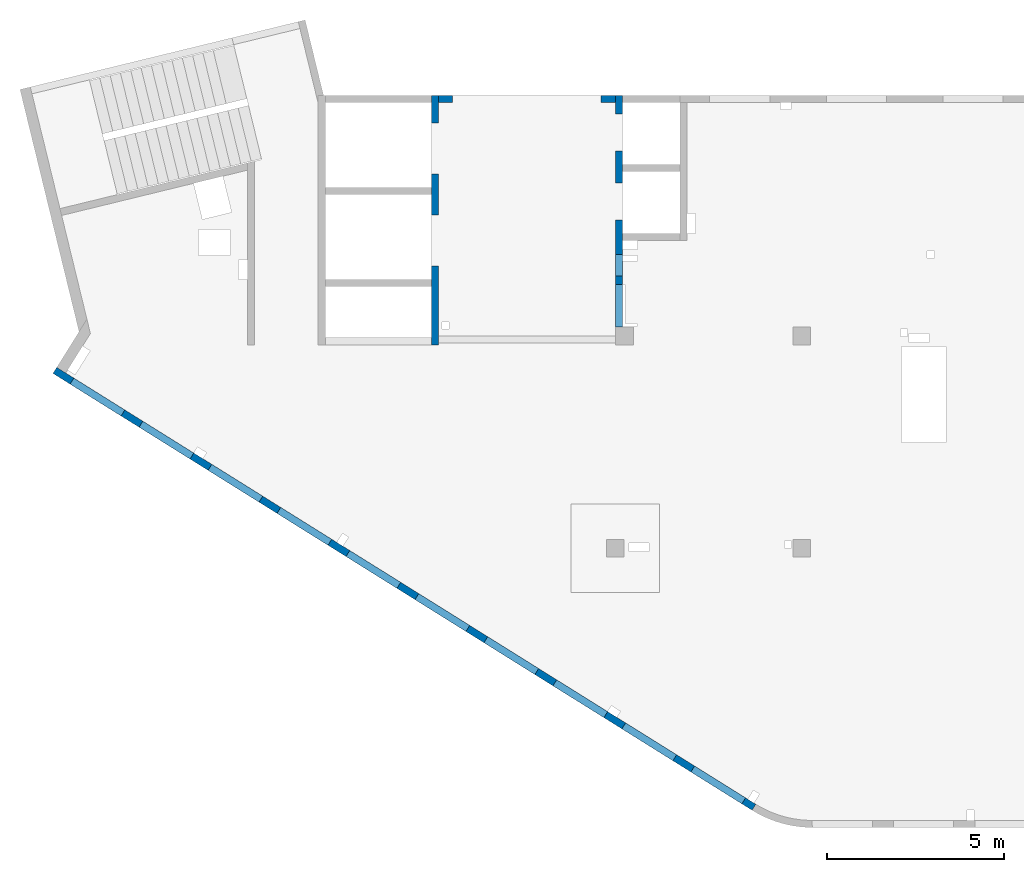
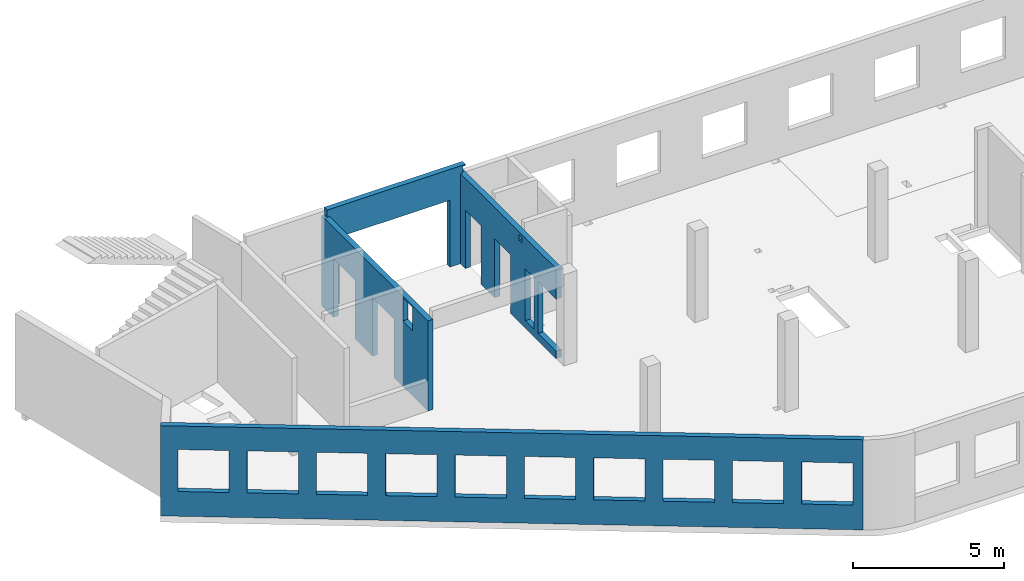
# One storey, part 4 of 6: 4 walls, 19 openings.
"""IFC4 building model written with IfcOpenShell, lengths in millimetres."""

from ifc_helpers import new_model, entity, si_unit, converted_unit, derived_unit, direction, frame, origin, place, context, subcontext, project, spatial, indexed_curve, outline, extrude, polygons, material, type_object, element, save


model = new_model("IFC4")

# Units and contexts
model_context = context("Model", 3, precision=0.01, world=origin(), true_north=direction((6.12303176911189e-17, 1.0)))
plan_context = context("Plan", 3, precision=0.01, world=origin(), true_north=direction((6.12303176911189e-17, 1.0)))
body_context = subcontext(model_context, "Body", "Model", "MODEL_VIEW")
ifc_project = project(units=[si_unit("LENGTHUNIT", "METRE", prefix="MILLI"), si_unit("AREAUNIT", "SQUARE_METRE"), si_unit("VOLUMEUNIT", "CUBIC_METRE"), converted_unit("PLANEANGLEUNIT", "DEGREE", entity("IfcRatioMeasure", 0.0174532925199433), si_unit("PLANEANGLEUNIT", "RADIAN"), dimensions=[0, 0, 0, 0, 0, 0, 0]), si_unit("MASSUNIT", "GRAM", prefix="KILO"), derived_unit("MASSDENSITYUNIT", [(si_unit("MASSUNIT", "GRAM", prefix="KILO"), 1), (si_unit("LENGTHUNIT", "METRE"), -3)]), derived_unit("MOMENTOFINERTIAUNIT", [(si_unit("LENGTHUNIT", "METRE"), 4)]), si_unit("TIMEUNIT", "SECOND"), si_unit("FREQUENCYUNIT", "HERTZ"), si_unit("THERMODYNAMICTEMPERATUREUNIT", "DEGREE_CELSIUS"), derived_unit("THERMALTRANSMITTANCEUNIT", [(si_unit("MASSUNIT", "GRAM", prefix="KILO"), 1), (si_unit("THERMODYNAMICTEMPERATUREUNIT", "KELVIN"), -1), (si_unit("TIMEUNIT", "SECOND"), -3)]), derived_unit("VOLUMETRICFLOWRATEUNIT", [(si_unit("LENGTHUNIT", "METRE"), 3), (si_unit("TIMEUNIT", "SECOND"), -1)]), derived_unit("MASSFLOWRATEUNIT", [(si_unit("MASSUNIT", "GRAM", prefix="KILO"), 1), (si_unit("TIMEUNIT", "SECOND"), -1)]), derived_unit("ROTATIONALFREQUENCYUNIT", [(si_unit("TIMEUNIT", "SECOND"), -1)]), si_unit("ELECTRICCURRENTUNIT", "AMPERE"), si_unit("ELECTRICVOLTAGEUNIT", "VOLT"), si_unit("POWERUNIT", "WATT"), si_unit("FORCEUNIT", "NEWTON", prefix="KILO"), si_unit("ILLUMINANCEUNIT", "LUX"), si_unit("LUMINOUSFLUXUNIT", "LUMEN"), si_unit("LUMINOUSINTENSITYUNIT", "CANDELA"), derived_unit("USERDEFINED", [(si_unit("MASSUNIT", "GRAM", prefix="KILO"), -1), (si_unit("LENGTHUNIT", "METRE"), -2), (si_unit("TIMEUNIT", "SECOND"), 3), (si_unit("LUMINOUSFLUXUNIT", "LUMEN"), 1)]), derived_unit("LINEARVELOCITYUNIT", [(si_unit("LENGTHUNIT", "METRE"), 1), (si_unit("TIMEUNIT", "SECOND"), -1)]), si_unit("PRESSUREUNIT", "PASCAL"), derived_unit("USERDEFINED", [(si_unit("LENGTHUNIT", "METRE"), -2), (si_unit("MASSUNIT", "GRAM", prefix="KILO"), 1), (si_unit("TIMEUNIT", "SECOND"), -2)]), derived_unit("LINEARFORCEUNIT", [(si_unit("MASSUNIT", "GRAM", prefix="KILO"), 1), (si_unit("LENGTHUNIT", "METRE"), 1), (si_unit("TIMEUNIT", "SECOND"), -2), (si_unit("LENGTHUNIT", "METRE"), -1)]), derived_unit("PLANARFORCEUNIT", [(si_unit("MASSUNIT", "GRAM", prefix="KILO"), 1), (si_unit("LENGTHUNIT", "METRE"), 1), (si_unit("TIMEUNIT", "SECOND"), -2), (si_unit("LENGTHUNIT", "METRE"), -2)])], contexts=[model_context, plan_context])

# Site, building, storey
site_placement = place(None, origin())
site = spatial("IfcSite", under=ifc_project, at=site_placement, CompositionType="ELEMENT")
building_placement = place(site_placement, origin())
building = spatial("IfcBuilding", under=site, at=building_placement, CompositionType="ELEMENT")
storey_placement = place(building_placement, frame((0.0, 0.0, 8100.0)))
storey = spatial("IfcBuildingStorey", under=building, at=storey_placement, CompositionType="ELEMENT", Elevation=8100.0)

# Wall, openings
ifc_material = material()
wall_type = type_object("IfcWallType", PredefinedType="STANDARD")
wall_1_placement = place(storey_placement, frame((19822.3508929728, 371.159406986362, -150.0), z_axis=(0.0, 0.0, 1.0), x_axis=(-0.848052743777574, 0.529911826412025, 0.0)))
wall_1 = element("IfcWall", 1, at=wall_1_placement, inside=storey, type_object=wall_type, material=ifc_material, PredefinedType="NOTDEFINED", context=body_context, shape_type="Tessellation", body=[
    polygons([(341.63903172165, -99.9999999999988, 2700.0), (2041.63903172165, -99.9999999999981, 2700.0), (2041.63903172165, -99.9999999999981, 1000.00000000001), (341.63903172165, -99.9999999999988, 1000.00000000001), (2641.63903172165, -99.9999999999995, 2700.0), (4341.63903172165, -99.9999999999992, 2700.0), (4341.63903172165, -99.9999999999992, 1000.00000000001), (2641.63903172165, -99.9999999999995, 1000.00000000001), (4941.63903172166, -100.0, 2700.0), (6641.63903172166, -99.9999999999984, 2700.0), (6641.63903172166, -99.9999999999984, 1000.00000000001), (4941.63903172166, -100.0, 1000.00000000001), (7241.63903172167, -99.9999999999984, 2700.0), (8941.63903172167, -100.0, 2700.0), (8941.63903172167, -100.0, 1000.00000000001), (7241.63903172167, -99.9999999999984, 1000.00000000001), (9541.63903172167, -100.0, 2700.0), (11241.6390317217, -99.9999999999989, 2700.0), (11241.6390317217, -99.9999999999989, 1000.00000000001), (9541.63903172167, -100.0, 1000.00000000001), (11841.6390317217, -100.0, 2700.0), (13541.6390317217, -100.0, 2700.0), (13541.6390317217, -100.0, 1000.00000000001), (11841.6390317217, -100.0, 1000.00000000001), (14141.6390317217, -100.0, 2700.0), (15841.6390317217, -100.0, 2700.0), (15841.6390317217, -100.0, 1000.00000000001), (14141.6390317217, -100.0, 1000.00000000001), (16441.6390317217, -99.9999999999989, 2700.0), (18141.6390317217, -99.9999999999989, 2700.0), (18141.6390317217, -99.9999999999989, 1000.00000000001), (16441.6390317217, -99.9999999999989, 1000.00000000001), (18741.6390317217, -100.0, 2700.0), (20441.6390317217, -99.9999999999989, 2700.0), (20441.6390317217, -99.9999999999989, 1000.00000000001), (18741.6390317217, -100.0, 1000.00000000001), (21041.6390317217, -99.9999999999989, 2700.0), (22741.6390317217, -100.000000000001, 2700.0), (22741.6390317217, -100.000000000001, 1000.00000000001), (21041.6390317217, -99.9999999999989, 1000.00000000001), (-1.48894230278529e-12, -99.9999999999978, 0.0), (66.6340806380096, -99.9999999999985, 0.0), (266.636711734731, -99.9999999999993, 0.0), (4641.63671190304, -99.9999999999984, 0.0), (4941.63495785519, -100.0, 0.0), (13771.6340811649, -99.9999999999989, 0.0), (13971.6367122616, -100.000000000001, 0.0), (18441.6367124338, -100.0, 0.0), (18741.6390317217, -100.0, 0.0), (23011.6394501553, -99.9999999999989, 0.0), (23311.6394501553, -99.9999999999989, 0.0), (23311.6394501553, -99.9999999999989, 3650.0), (23011.6394501553, -99.9999999999989, 3650.0), (-1.48894230278529e-12, -99.9999999999978, 3650.0), (-2.26725305196851e-12, 100.000000000001, 0.0), (-2.26725305196851e-12, 100.000000000001, 3650.0), (23311.6394501553, 100.000000000001, 3650.0), (23311.6394501553, 99.9999999999989, 0.0), (2041.63903172165, 100.000000000323, 2700.0), (341.63903172165, 100.000000000321, 2700.0), (341.63903172165, 100.000000000321, 1000.00000000001), (2041.63903172165, 100.000000000323, 1000.00000000001), (4341.63903172165, 100.000000000322, 2700.0), (2641.63903172165, 100.00000000032, 2700.0), (2641.63903172165, 100.00000000032, 1000.00000000001), (4341.63903172165, 100.000000000322, 1000.00000000001), (6641.63903172166, 100.000000000322, 2700.0), (4941.63903172166, 100.000000000321, 2700.0), (4941.63903172166, 100.000000000321, 1000.00000000001), (6641.63903172166, 100.000000000322, 1000.00000000001), (8941.63903172166, 100.000000000321, 2700.0), (7241.63903172167, 100.000000000322, 2700.0), (7241.63903172167, 100.000000000322, 1000.00000000001), (8941.63903172166, 100.000000000321, 1000.00000000001), (11241.6390317217, 100.000000000323, 2700.0), (9541.63903172167, 100.000000000321, 2700.0), (9541.63903172167, 100.000000000321, 1000.00000000001), (11241.6390317217, 100.000000000323, 1000.00000000001), (13541.6390317217, 100.000000000319, 2700.0), (11841.6390317217, 100.000000000323, 2700.0), (11841.6390317217, 100.000000000323, 1000.00000000001), (13541.6390317217, 100.000000000319, 1000.00000000001), (15841.6390317217, 100.000000000322, 2700.0), (14141.6390317217, 100.000000000322, 2700.0), (14141.6390317217, 100.000000000322, 1000.00000000001), (15841.6390317217, 100.000000000322, 1000.00000000001), (18141.6390317217, 100.000000000322, 2700.0), (16441.6390317217, 100.000000000322, 2700.0), (16441.6390317217, 100.000000000322, 1000.00000000001), (18141.6390317217, 100.000000000322, 1000.00000000001), (20441.6390317217, 100.000000000322, 2700.0), (18741.6390317217, 100.000000000319, 2700.0), (18741.6390317217, 100.000000000319, 1000.00000000001), (20441.6390317217, 100.000000000322, 1000.00000000001), (22741.6390317217, 100.000000000319, 2700.0), (21041.6390317217, 100.000000000321, 2700.0), (21041.6390317217, 100.000000000323, 1000.00000000001), (22741.6390317217, 100.000000000319, 1000.00000000001)], [[[41, 42, 43, 44, 45, 46, 47, 48, 49, 50, 51, 52, 53, 54], [1, 2, 3, 4], [5, 6, 7, 8], [9, 10, 11, 12], [13, 14, 15, 16], [17, 18, 19, 20], [21, 22, 23, 24], [25, 26, 27, 28], [29, 30, 31, 32], [33, 34, 35, 36], [37, 38, 39, 40]], [[55, 56, 57, 58], [59, 60, 61, 62], [63, 64, 65, 66], [67, 68, 69, 70], [71, 72, 73, 74], [75, 76, 77, 78], [79, 80, 81, 82], [83, 84, 85, 86], [87, 88, 89, 90], [91, 92, 93, 94], [95, 96, 97, 98]], [[51, 50, 49, 48, 47, 46, 45, 44, 43, 42, 41, 55, 58]], [[54, 53, 52, 57, 56]], [[41, 54, 56, 55]], [[52, 51, 58, 57]], [[60, 59, 2, 1]], [[60, 1, 4, 61]], [[61, 4, 3, 62]], [[2, 59, 62, 3]], [[64, 63, 6, 5]], [[64, 5, 8, 65]], [[65, 8, 7, 66]], [[6, 63, 66, 7]], [[68, 67, 10, 9]], [[68, 9, 12, 69]], [[69, 12, 11, 70]], [[10, 67, 70, 11]], [[72, 71, 14, 13]], [[72, 13, 16, 73]], [[73, 16, 15, 74]], [[14, 71, 74, 15]], [[76, 75, 18, 17]], [[76, 17, 20, 77]], [[77, 20, 19, 78]], [[18, 75, 78, 19]], [[80, 79, 22, 21]], [[80, 21, 24, 81]], [[81, 24, 23, 82]], [[22, 79, 82, 23]], [[84, 83, 26, 25]], [[84, 25, 28, 85]], [[85, 28, 27, 86]], [[26, 83, 86, 27]], [[88, 87, 30, 29]], [[88, 29, 32, 89]], [[89, 32, 31, 90]], [[30, 87, 90, 31]], [[92, 91, 34, 33]], [[92, 33, 36, 93]], [[93, 36, 35, 94]], [[34, 91, 94, 35]], [[96, 95, 38, 37]], [[96, 37, 40, 97]], [[97, 40, 39, 98]], [[38, 95, 98, 39]]], closed=True),
])
opening_1_placement = place(wall_1_placement, frame((16613.7173036613, 10818.8609189489, 150.0), z_axis=(0.0, 0.0, 1.0), x_axis=(-0.848052743777574, -0.529911826412026, 0.0)))
element("IfcOpeningElement", 2, at=opening_1_placement, cuts=wall_1, PredefinedType="OPENING", context=body_context, shape_type="SweptSolid", body=[
    extrude(outline(indexed_curve([(-849.999999999993, -850.0), (849.999999999994, -850.0), (849.999999999994, 850.0), (-849.999999999993, 850.0), (-849.999999999993, -850.0)], self_intersect=False)), frame((1310.07752897417, 12056.6031038165, 1700.0), z_axis=(-0.529911826412026, -0.848052743777574, 0.0), x_axis=(0.0, 0.0, -1.0)), (0.0, 0.0, 1.0), 200.000000000964),
])
opening_2_placement = place(wall_1_placement, frame((16613.7173036613, 10818.8609189489, 150.0), z_axis=(0.0, 0.0, 1.0), x_axis=(-0.848052743777574, -0.529911826412026, 0.0)))
element("IfcOpeningElement", 3, at=opening_2_placement, cuts=wall_1, PredefinedType="OPENING", context=body_context, shape_type="SweptSolid", body=[
    extrude(outline(indexed_curve([(-849.999999999993, -850.0), (849.999999999994, -850.0), (849.999999999994, 850.0), (-849.999999999993, 850.0), (-849.999999999993, -850.0)], self_intersect=False)), frame((3260.5988396626, 10837.8059030689, 1700.0), z_axis=(-0.529911826412026, -0.848052743777574, 0.0), x_axis=(0.0, 0.0, -1.0)), (0.0, 0.0, 1.0), 200.000000000964),
])
opening_3_placement = place(wall_1_placement, frame((16613.7173036613, 10818.8609189489, 150.0), z_axis=(0.0, 0.0, 1.0), x_axis=(-0.848052743777574, -0.529911826412026, 0.0)))
element("IfcOpeningElement", 4, at=opening_3_placement, cuts=wall_1, PredefinedType="OPENING", context=body_context, shape_type="SweptSolid", body=[
    extrude(outline(indexed_curve([(-849.999999999993, -850.0), (849.999999999994, -850.0), (849.999999999994, 850.0), (-849.999999999993, 850.0), (-849.999999999993, -850.0)], self_intersect=False)), frame((5211.12015035101, 9619.00870232123, 1700.0), z_axis=(-0.529911826412025, -0.848052743777574, 0.0), x_axis=(0.0, 0.0, -1.0)), (0.0, 0.0, 1.0), 200.000000000962),
])
opening_4_placement = place(wall_1_placement, frame((16613.7173036613, 10818.8609189489, 150.0), z_axis=(0.0, 0.0, 1.0), x_axis=(-0.848052743777574, -0.529911826412026, 0.0)))
element("IfcOpeningElement", 5, at=opening_4_placement, cuts=wall_1, PredefinedType="OPENING", context=body_context, shape_type="SweptSolid", body=[
    extrude(outline(indexed_curve([(-849.999999999993, -849.999999999999), (849.999999999994, -849.999999999999), (849.999999999994, 850.0), (-849.999999999993, 850.0), (-849.999999999993, -849.999999999999)], self_intersect=False)), frame((7161.64146103944, 8400.21150157357, 1700.0), z_axis=(-0.529911826412026, -0.848052743777574, 0.0), x_axis=(0.0, 0.0, -1.0)), (0.0, 0.0, 1.0), 200.000000000962),
])
opening_5_placement = place(wall_1_placement, frame((16613.7173036613, 10818.8609189489, 150.0), z_axis=(0.0, 0.0, 1.0), x_axis=(-0.848052743777574, -0.529911826412026, 0.0)))
element("IfcOpeningElement", 6, at=opening_5_placement, cuts=wall_1, PredefinedType="OPENING", context=body_context, shape_type="SweptSolid", body=[
    extrude(outline(indexed_curve([(-849.999999999993, -849.999999999999), (849.999999999994, -849.999999999999), (849.999999999994, 850.0), (-849.999999999993, 850.0), (-849.999999999993, -849.999999999999)], self_intersect=False)), frame((9112.16277172786, 7181.41430082591, 1700.0), z_axis=(-0.529911826412026, -0.848052743777574, 0.0), x_axis=(0.0, 0.0, -1.0)), (0.0, 0.0, 1.0), 200.000000000962),
])
opening_6_placement = place(wall_1_placement, frame((16613.7173036613, 10818.8609189489, 150.0), z_axis=(0.0, 0.0, 1.0), x_axis=(-0.848052743777574, -0.529911826412026, 0.0)))
element("IfcOpeningElement", 7, at=opening_6_placement, cuts=wall_1, PredefinedType="OPENING", context=body_context, shape_type="SweptSolid", body=[
    extrude(outline(indexed_curve([(-849.999999999993, -850.0), (849.999999999994, -850.0), (849.999999999994, 850.0), (-849.999999999993, 850.0), (-849.999999999993, -850.0)], self_intersect=False)), frame((11062.6840824163, 5962.61710007824, 1700.0), z_axis=(-0.529911826412025, -0.848052743777574, 0.0), x_axis=(0.0, 0.0, -1.0)), (0.0, 0.0, 1.0), 200.000000000964),
])
opening_7_placement = place(wall_1_placement, frame((16613.7173036613, 10818.8609189489, 150.0), z_axis=(0.0, 0.0, 1.0), x_axis=(-0.848052743777574, -0.529911826412026, 0.0)))
element("IfcOpeningElement", 8, at=opening_7_placement, cuts=wall_1, PredefinedType="OPENING", context=body_context, shape_type="SweptSolid", body=[
    extrude(outline(indexed_curve([(-849.999999999993, -850.0), (849.999999999994, -850.0), (849.999999999994, 850.0), (-849.999999999993, 850.0), (-849.999999999993, -850.0)], self_intersect=False)), frame((13013.2053931047, 4743.81989933058, 1700.0), z_axis=(-0.529911826412025, -0.848052743777574, 0.0), x_axis=(0.0, 0.0, -1.0)), (0.0, 0.0, 1.0), 200.000000000959),
])
opening_8_placement = place(wall_1_placement, frame((16613.7173036613, 10818.8609189489, 150.0), z_axis=(0.0, 0.0, 1.0), x_axis=(-0.848052743777574, -0.529911826412026, 0.0)))
element("IfcOpeningElement", 9, at=opening_8_placement, cuts=wall_1, PredefinedType="OPENING", context=body_context, shape_type="SweptSolid", body=[
    extrude(outline(indexed_curve([(-849.999999999993, -850.000000000002), (849.999999999994, -850.000000000002), (849.999999999994, 849.999999999998), (-849.999999999993, 849.999999999998), (-849.999999999993, -850.000000000002)], self_intersect=False)), frame((14963.7267037931, 3525.02269858292, 1700.0), z_axis=(-0.529911826412025, -0.848052743777574, 0.0), x_axis=(0.0, 0.0, -1.0)), (0.0, 0.0, 1.0), 200.000000000962),
])
opening_9_placement = place(wall_1_placement, frame((16613.7173036613, 10818.8609189489, 150.0), z_axis=(0.0, 0.0, 1.0), x_axis=(-0.848052743777574, -0.529911826412026, 0.0)))
element("IfcOpeningElement", 10, at=opening_9_placement, cuts=wall_1, PredefinedType="OPENING", context=body_context, shape_type="SweptSolid", body=[
    extrude(outline(indexed_curve([(-849.999999999993, -850.0), (849.999999999994, -850.0), (849.999999999994, 850.0), (-849.999999999993, 850.0), (-849.999999999993, -850.0)], self_intersect=False)), frame((16914.2480144816, 2306.22549783526, 1700.0), z_axis=(-0.529911826412025, -0.848052743777574, 0.0), x_axis=(0.0, 0.0, -1.0)), (0.0, 0.0, 1.0), 200.000000000962),
])
opening_10_placement = place(wall_1_placement, frame((16613.7173036613, 10818.8609189489, 150.0), z_axis=(0.0, 0.0, 1.0), x_axis=(-0.848052743777574, -0.529911826412026, 0.0)))
element("IfcOpeningElement", 11, at=opening_10_placement, cuts=wall_1, PredefinedType="OPENING", context=body_context, shape_type="SweptSolid", body=[
    extrude(outline(indexed_curve([(-849.999999999993, -850.0), (849.999999999994, -850.0), (849.999999999994, 850.0), (-849.999999999993, 850.0), (-849.999999999993, -850.0)], self_intersect=False)), frame((18864.76932517, 1087.4282970876, 1700.0), z_axis=(-0.529911826412025, -0.848052743777574, 0.0), x_axis=(0.0, 0.0, -1.0)), (0.0, 0.0, 1.0), 200.000000000966),
])

wall_2_placement = place(storey_placement, frame((16000.0002685547, 20499.9998657227, -150.0), z_axis=(0.0, 0.0, 1.0), x_axis=(0.0, -1.0, 0.0)))
wall_2 = element("IfcWall", 12, at=wall_2_placement, inside=storey, type_object=wall_type, material=ifc_material, PredefinedType="NOTDEFINED", context=body_context, shape_type="Tessellation", body=[
    polygons([(4100.00063936683, -100.000000000321, 3550.0), (4300.00063936683, -100.00000000032, 3550.0), (4300.00063936683, -100.00000000032, 3300.00000000001), (4100.00063936683, -100.000000000321, 3300.00000000001), (4500.00063936683, -99.9999999999995, 2399.99999999999), (5100.00063936683, -100.000000000001, 2399.99999999999), (5100.00063936683, -100.000000000001, 300.000000000001), (4500.00063936683, -99.9999999999995, 300.000000000001), (6550.00048980714, -99.9999999999982, 3650.0), (400.000000000009, -99.9999999999998, 3650.0), (200.000000000002, -100.0, 3650.0), (0.0, -100.0, 3650.0), (0.0, -100.0, 0.0), (200.000000000002, -100.0, 0.0), (529.999999999996, -99.9999999999995, 0.0), (529.999999999996, -99.9999999999995, 2369.99999999805), (1570.0, -100.000000000002, 2369.99999999805), (1570.0, -100.000000000002, 0.0), (2480.0, -100.000000000001, 0.0), (2480.0, -100.000000000001, 2369.99999999805), (3519.99999999999, -100.000000000001, 2369.99999999805), (3519.99999999999, -100.000000000001, 0.0), (6550.00048980714, -99.9999999999982, 0.0), (6550.00048980714, -99.9999999999982, 300.000000000001), (5350.00048980714, -100.0, 300.000000000001), (5350.00048980714, -100.0, 2399.99999999999), (6550.00048980714, -99.9999999999982, 2399.99999999999), (4300.00063936683, 100.0, 3550.0), (4100.00063936683, 99.9999999999999, 3550.0), (4100.00063936683, 99.9999999999999, 3300.00000000001), (4300.00063936683, 100.0, 3300.00000000001), (5100.00063936683, 99.9999999999994, 2399.99999999999), (4500.00063936683, 99.9999999999984, 2399.99999999998), (4500.00063936683, 99.9999999999984, 300.000000000001), (5100.00063936683, 99.9999999999994, 300.000000000001), (0.0, 99.9999999999996, 3650.0), (200.000000000002, 99.9999999999999, 3650.0), (3900.00063936685, 99.9999999999995, 3650.0), (4100.00063936685, 99.9999999999999, 3650.0), (4300.00063936685, 100.0, 3650.0), (4525.00063936685, 100.000000000001, 3650.0), (4685.00063936685, 99.9999999999987, 3650.0), (5340.00063936685, 99.9999999999998, 3650.0), (6530.00063936685, 99.9999999999996, 3650.0), (6550.00048980714, 99.9999999999996, 3650.0), (6550.00048980714, 99.9999999999996, 2399.99999999999), (5350.00048980714, 99.9999999999998, 2399.99999999998), (5350.00048980714, 99.9999999999998, 300.000000000001), (6550.00048980714, 99.9999999999996, 300.000000000001), (6550.00048980714, 99.9999999999996, 0.0), (4100.00063936683, 99.9999999999999, 0.0), (3900.00063936683, 99.9999999999995, 0.0), (3519.99999999999, 99.9999999999989, 0.0), (3519.99999999999, 99.9999999999989, 2369.99999999805), (2480.0, 100.000000000002, 2369.99999999804), (2480.0, 100.000000000002, 0.0), (1570.0, 100.0, 0.0), (1570.0, 100.0, 2369.99999999805), (529.999999999996, 100.0, 2369.99999999804), (529.999999999996, 100.0, 0.0), (0.0, 99.9999999999996, 0.0), (0.0, 6.56688670961758e-13, 3650.0)], [[[9, 10, 11, 12, 13, 14, 15, 16, 17, 18, 19, 20, 21, 22, 23, 24, 25, 26, 27], [1, 2, 3, 4], [5, 6, 7, 8]], [[36, 37, 38, 39, 40, 41, 42, 43, 44, 45, 46, 47, 48, 49, 50, 51, 52, 53, 54, 55, 56, 57, 58, 59, 60, 61], [28, 29, 30, 31], [32, 33, 34, 35]], [[13, 61, 60, 15, 14]], [[23, 50, 49, 24]], [[12, 11, 10, 9, 45, 44, 43, 42, 41, 40, 39, 38, 37, 36, 62]], [[13, 12, 62, 36, 61]], [[2, 1, 29, 28]], [[2, 28, 31, 3]], [[3, 31, 30, 4]], [[29, 1, 4, 30]], [[32, 6, 5, 33]], [[33, 5, 8, 34]], [[34, 8, 7, 35]], [[6, 32, 35, 7]], [[26, 47, 46, 27]], [[47, 26, 25, 48]], [[48, 25, 24, 49]], [[54, 21, 20, 55]], [[55, 20, 19, 56]], [[21, 54, 53, 22]], [[58, 17, 16, 59]], [[59, 16, 15, 60]], [[17, 58, 57, 18]], [[45, 9, 27, 46]], [[56, 19, 18, 57]], [[50, 23, 22, 53, 52, 51]]], closed=True),
])
opening_11_placement = place(wall_2_placement, frame((20499.9998657227, -16000.0002685547, 150.0), z_axis=(0.0, 0.0, 1.0), x_axis=(0.0, 1.0, 0.0)))
element("IfcOpeningElement", 13, at=opening_11_placement, cuts=wall_2, PredefinedType="OPENING", context=body_context, shape_type="SweptSolid", body=[
    extrude(outline(indexed_curve([(-1049.99999999999, -600.0), (1049.99999999999, -600.0), (1049.99999999999, 600.0), (-1049.99999999999, 600.0), (-1049.99999999999, -600.0)], self_intersect=False)), frame((15800.0002685547, 14549.9993759155, 1200.0), z_axis=(1.0, 0.0, 0.0), x_axis=(0.0, 0.0, -1.0)), (0.0, 0.0, 1.0), 400.000000001943),
])
opening_12_placement = place(wall_2_placement, frame((20499.9998657227, -16000.0002685547, 150.0), z_axis=(0.0, 0.0, 1.0), x_axis=(0.0, 1.0, 0.0)))
element("IfcOpeningElement", 14, at=opening_12_placement, cuts=wall_2, PredefinedType="OPENING", context=body_context, shape_type="SweptSolid", body=[
    extrude(outline(indexed_curve([(-1184.99999999902, -520.000000000001), (1184.99999999902, -520.000000000001), (1184.99999999902, 519.999999999999), (-1184.99999999902, 519.999999999999), (-1184.99999999902, -520.000000000001)], self_intersect=False)), frame((15800.0002685547, 17499.9998657227, 1035.0), z_axis=(1.0, 0.0, 0.0), x_axis=(0.0, 0.0, -1.0)), (0.0, 0.0, 1.0), 400.000000001943),
])
opening_13_placement = place(wall_2_placement, frame((20499.9998657227, -16000.0002685547, 150.0), z_axis=(0.0, 0.0, 1.0), x_axis=(0.0, 1.0, 0.0)))
element("IfcOpeningElement", 15, at=opening_13_placement, cuts=wall_2, PredefinedType="OPENING", context=body_context, shape_type="SweptSolid", body=[
    extrude(outline(indexed_curve([(-1184.99999999902, -519.999999999999), (1184.99999999902, -519.999999999999), (1184.99999999902, 520.000000000001), (-1184.99999999902, 520.000000000001), (-1184.99999999902, -519.999999999999)], self_intersect=False)), frame((15800.0002685547, 19449.9998657227, 1035.0), z_axis=(1.0, 0.0, 0.0), x_axis=(0.0, 0.0, -1.0)), (0.0, 0.0, 1.0), 400.000000001943),
])
opening_14_placement = place(wall_2_placement, frame((20499.9998657227, -16000.0002685547, 150.0), z_axis=(0.0, 0.0, 1.0), x_axis=(0.0, 1.0, 0.0)))
element("IfcOpeningElement", 16, at=opening_14_placement, cuts=wall_2, PredefinedType="OPENING", context=body_context, shape_type="SweptSolid", body=[
    extrude(outline(indexed_curve([(-100.000000000001, -124.999999999993), (99.9999999999989, -124.999999999993), (99.9999999999989, 124.999999999993), (-100.000000000001, 124.999999999993), (-100.000000000001, -124.999999999993)], self_intersect=False)), frame((15900.0002685537, 16299.9992263558, 3275.0), z_axis=(1.0, 0.0, 0.0), x_axis=(0.0, -1.0, 0.0)), (0.0, 0.0, 1.0), 200.000000000962),
])
opening_15_placement = place(wall_2_placement, frame((20499.9998657227, -16000.0002685547, 150.0), z_axis=(0.0, 0.0, 1.0), x_axis=(0.0, 1.0, 0.0)))
element("IfcOpeningElement", 17, at=opening_15_placement, cuts=wall_2, PredefinedType="OPENING", context=body_context, shape_type="SweptSolid", body=[
    extrude(outline(indexed_curve([(-1049.99999999999, -300.000000000001), (1049.99999999999, -300.000000000001), (1049.99999999999, 299.999999999999), (-1049.99999999999, 299.999999999999), (-1049.99999999999, -300.000000000001)], self_intersect=False)), frame((15800.0002685547, 15699.9992263558, 1200.0), z_axis=(1.0, 0.0, 0.0), x_axis=(0.0, 0.0, -1.0)), (0.0, 0.0, 1.0), 400.000000001943),
])

wall_3_placement = place(storey_placement, frame((10800.0002685547, 20499.9998657227, -150.0), z_axis=(0.0, 0.0, 1.0), x_axis=(0.0, -1.0, 0.0)))
wall_3 = element("IfcWall", 18, at=wall_3_placement, inside=storey, type_object=wall_type, material=ifc_material, PredefinedType="NOTDEFINED", context=body_context, shape_type="Tessellation", body=[
    polygons([(5400.00000000002, -99.999999999999, 3600.0), (6050.00000000002, -99.9999999999979, 3600.0), (6050.00000000002, -99.9999999999979, 2650.00000000001), (5400.00000000002, -99.999999999999, 2650.00000000001), (7050.00063936683, -99.9999999999985, 3650.0), (6850.00063936682, -99.9999999999988, 3650.0), (200.000000000028, -99.9999999999985, 3650.0), (0.0, -99.9999999999988, 3650.0), (0.0, -99.9999999999988, 0.0), (780.000000000018, -99.9999999999976, 0.0), (780.000000000018, -99.9999999999976, 2369.99999999805), (2220.00000000001, -99.9999999999975, 2369.99999999804), (2220.00000000001, -99.9999999999997, 0.0), (3380.00000000002, -99.9999999999978, 0.0), (3380.00000000002, -99.9999999999978, 2369.99999999805), (4820.00000000001, -99.9999999999977, 2369.99999999805), (4820.00000000001, -99.9999999999977, 0.0), (6850.00063936683, -99.9999999999988, 0.0), (7050.00063936683, -99.9999999999985, 0.0), (7050.00063936683, -99.9999999999985, 1200.0), (0.0, 100.000000000001, 3650.0), (200.000000000002, 100.000000000001, 3650.0), (400.00000000003, 100.000000000002, 3650.0), (6400.00063936682, 100.0, 3650.0), (6600.00063936682, 100.000000000001, 3650.0), (7050.00063936683, 100.000000000001, 3650.0), (7050.00063936683, 100.000000000001, 0.0), (4820.00000000001, 100.000000000002, 0.0), (4820.00000000002, 100.000000000002, 2369.99999999805), (3380.00000000002, 100.000000000002, 2369.99999999804), (3380.00000000002, 100.000000000002, 0.0), (2220.00000000001, 100.000000000003, 0.0), (2220.00000000001, 100.000000000003, 2369.99999999805), (780.000000000018, 100.000000000002, 2369.99999999805), (780.000000000018, 100.000000000002, 0.0), (200.000000000002, 100.000000000001, 0.0), (0.0, 100.000000000001, 0.0), (6050.00000000002, 100.000000000323, 3600.0), (5400.00000000002, 100.000000000322, 3600.0), (5400.00000000002, 100.000000000322, 2650.00000000001), (6050.00000000002, 100.000000000323, 2650.00000000001), (0.0, 7.90446333772861e-14, 3650.0)], [[[5, 6, 7, 8, 9, 10, 11, 12, 13, 14, 15, 16, 17, 18, 19, 20], [1, 2, 3, 4]], [[21, 22, 23, 24, 25, 26, 27, 28, 29, 30, 31, 32, 33, 34, 35, 36, 37], [38, 39, 40, 41]], [[9, 37, 36, 35, 10]], [[8, 7, 6, 5, 26, 25, 24, 23, 22, 21, 42]], [[9, 8, 42, 21, 37]], [[39, 38, 2, 1]], [[39, 1, 4, 40]], [[40, 4, 3, 41]], [[2, 38, 41, 3]], [[11, 34, 33, 12]], [[12, 33, 32, 13]], [[34, 11, 10, 35]], [[29, 16, 15, 30]], [[30, 15, 14, 31]], [[16, 29, 28, 17]], [[5, 20, 19, 27, 26]], [[13, 32, 31, 14]], [[27, 19, 18, 17, 28]]], closed=True),
])
opening_16_placement = place(wall_3_placement, frame((20499.9998657227, -10800.0002685547, 150.0), z_axis=(0.0, 0.0, 1.0), x_axis=(0.0, 1.0, 0.0)))
element("IfcOpeningElement", 19, at=opening_16_placement, cuts=wall_3, PredefinedType="OPENING", context=body_context, shape_type="SweptSolid", body=[
    extrude(outline(indexed_curve([(-719.999999999999, -1184.99999999902), (719.999999999999, -1184.99999999902), (719.999999999999, 1184.99999999902), (-719.999999999999, 1184.99999999902), (-719.999999999999, -1184.99999999902)], self_intersect=False)), frame((10600.0002685528, 18999.9998657227, 1035.0), z_axis=(1.0, 0.0, 0.0), x_axis=(0.0, -1.0, 0.0)), (0.0, 0.0, 1.0), 400.000000001943),
])
opening_17_placement = place(wall_3_placement, frame((20499.9998657227, -10800.0002685547, 150.0), z_axis=(0.0, 0.0, 1.0), x_axis=(0.0, 1.0, 0.0)))
element("IfcOpeningElement", 20, at=opening_17_placement, cuts=wall_3, PredefinedType="OPENING", context=body_context, shape_type="SweptSolid", body=[
    extrude(outline(indexed_curve([(-1184.99999999902, -719.999999999999), (1184.99999999902, -719.999999999999), (1184.99999999902, 720.000000000001), (-1184.99999999902, 720.000000000001), (-1184.99999999902, -719.999999999999)], self_intersect=False)), frame((10600.0002685547, 16399.9998657227, 1035.0), z_axis=(1.0, 0.0, 0.0), x_axis=(0.0, 0.0, -1.0)), (0.0, 0.0, 1.0), 400.000000001943),
])
opening_18_placement = place(wall_3_placement, frame((20499.9998657227, -10800.0002685547, 150.0), z_axis=(0.0, 0.0, 1.0), x_axis=(0.0, 1.0, 0.0)))
element("IfcOpeningElement", 21, at=opening_18_placement, cuts=wall_3, PredefinedType="OPENING", context=body_context, shape_type="SweptSolid", body=[
    extrude(outline(indexed_curve([(-474.999999999994, -325.0), (474.999999999992, -325.0), (474.999999999992, 325.0), (-474.999999999994, 325.0), (-474.999999999994, -325.0)], self_intersect=False)), frame((10700.0002685547, 14774.9998657227, 2975.0), z_axis=(1.0, 0.0, 0.0), x_axis=(0.0, 0.0, -1.0)), (0.0, 0.0, 1.0), 200.000000000962),
])

# Wall, opening
wall_4_placement = place(storey_placement, frame((10800.0002685547, 20399.9998657227, -150.0)))
wall_4 = element("IfcWall", 22, at=wall_4_placement, inside=storey, type_object=wall_type, material=ifc_material, PredefinedType="NOTDEFINED", context=body_context, shape_type="Tessellation", body=[
    polygons([(5300.00000000001, -100.000000000003, 3950.0), (5100.00000000001, -100.000000000003, 3950.0), (100.000000000001, -100.000000000003, 3950.0), (-4.99784381508401e-13, -100.000000000003, 3950.0), (-4.99784381508401e-13, -100.000000000003, 3900.0), (-4.99784381508401e-13, -100.000000000003, 3650.0), (100.000000000001, -100.000000000003, 3650.0), (100.000000000001, -100.000000000003, 0.0), (499.999999999992, -99.9999999999989, 0.0), (499.999999999994, -100.000000000003, 2699.99999999804), (4699.99999999999, -100.000000000003, 2699.99999999804), (4699.99999999999, -100.000000000003, 0.0), (5100.00000000001, -100.000000000003, 0.0), (5100.00000000001, -100.000000000003, 3650.0), (5200.00000000001, -100.000000000003, 3650.0), (5200.00000000001, -100.000000000003, 3900.0), (5300.00000000001, -100.000000000003, 3900.0), (-1.16616415338434e-12, 99.9999999999989, 3950.0), (99.9999999999999, 99.9999999999989, 3950.0), (5100.00000000001, 99.9999999999989, 3950.0), (5300.0, 99.9999999999989, 3950.0), (5300.0, 99.9999999999989, 3900.0), (5200.00000000001, 99.9999999999989, 3900.0), (5200.00000000001, 99.9999999999989, 3650.0), (5100.0, 99.9999999999989, 3650.0), (5100.0, 99.9999999999989, 0.0), (4699.99999999999, 99.9999999999989, 0.0), (4699.99999999999, 99.9999999999989, 2699.99999999804), (499.999999999993, 100.000000000003, 2699.99999999804), (499.999999999993, 100.000000000003, 0.0), (99.9999999999999, 99.9999999999989, 0.0), (99.9999999999999, 99.9999999999989, 3650.0), (-1.16616415338434e-12, 99.9999999999989, 3650.0), (-1.16616415338434e-12, 99.9999999999989, 3900.0)], [[[1, 2, 3, 4, 5, 6, 7, 8, 9, 10, 11, 12, 13, 14, 15, 16, 17]], [[18, 19, 20, 21, 22, 23, 24, 25, 26, 27, 28, 29, 30, 31, 32, 33, 34]], [[8, 31, 30, 9]], [[4, 3, 2, 1, 21, 20, 19, 18]], [[10, 29, 28, 11]], [[11, 28, 27, 12]], [[29, 10, 9, 30]], [[24, 15, 14, 25]], [[15, 24, 23, 16]], [[17, 16, 23, 22]], [[13, 26, 25, 14]], [[21, 1, 17, 22]], [[6, 33, 32, 7]], [[4, 18, 34, 33, 6, 5]], [[31, 8, 7, 32]], [[26, 13, 12, 27]]], closed=True),
])
opening_19_placement = place(wall_4_placement, frame((-10800.0002685547, -20399.9998657227, 150.0)))
element("IfcOpeningElement", 23, at=opening_19_placement, cuts=wall_4, PredefinedType="OPENING", context=body_context, shape_type="SweptSolid", body=[
    extrude(outline(indexed_curve([(-2100.0, -1349.99999999902), (2100.0, -1349.99999999902), (2100.0, 1349.99999999902), (-2100.0, 1349.99999999902), (-2100.0, -1349.99999999902)], self_intersect=False)), frame((13400.0002685547, 20199.9998657207, 1200.0), z_axis=(0.0, 1.0, 0.0), x_axis=(1.0, 0.0, 0.0)), (0.0, 0.0, 1.0), 400.000000001945),
])

save(model, "model.ifc")
